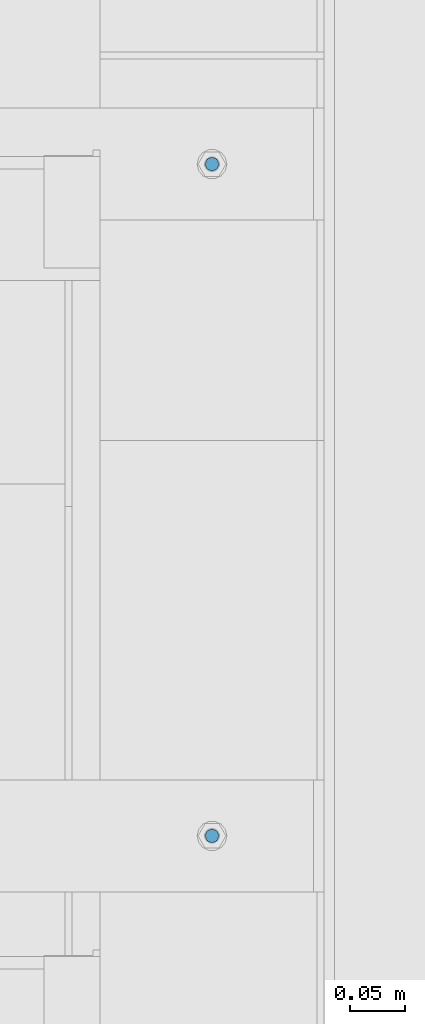
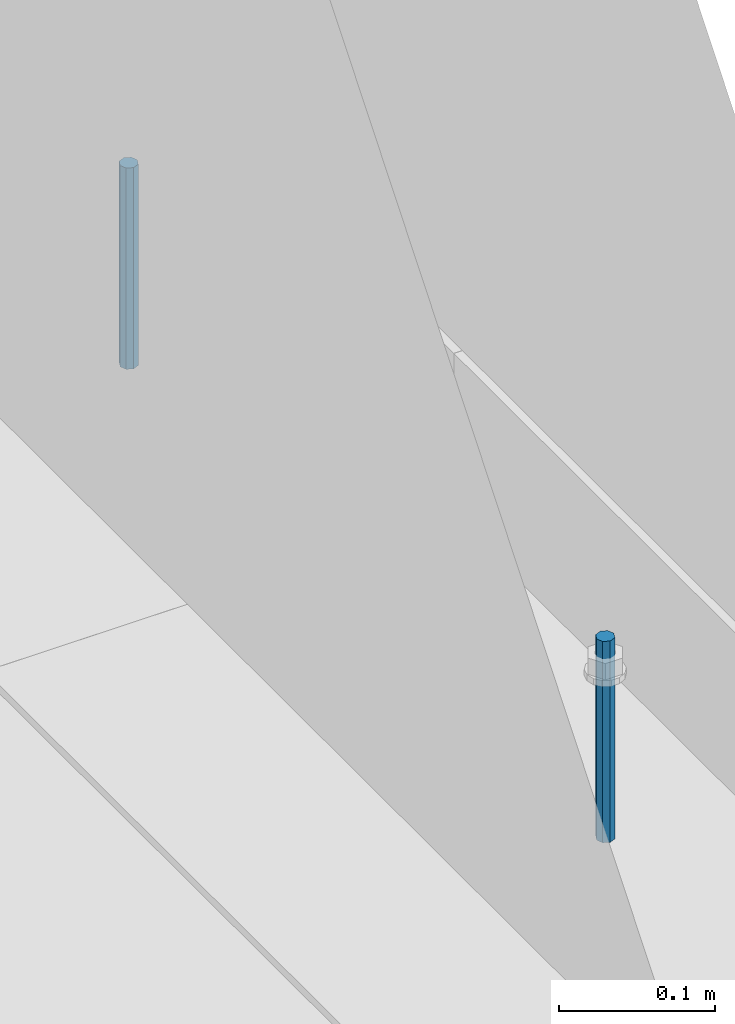
# One storey, part 462 of 1179: 2 columns, 1 element without a shape of its own.
"""IFC2X3 building model written with IfcOpenShell, lengths in millimetres."""

from ifc_helpers import new_model, si_unit, frame, origin_with_axes, place, context, subcontext, project, spatial, faceted_brep, material, type_object, element, aggregate, save


model = new_model("IFC2X3")

# Units and contexts
model_context = context("Model", 3, precision=1e-05, world=origin_with_axes())
body_context = subcontext(model_context, "Body", "Model", "MODEL_VIEW")
ifc_project = project(units=[si_unit("LENGTHUNIT", "METRE", prefix="MILLI"), si_unit("AREAUNIT", "SQUARE_METRE"), si_unit("VOLUMEUNIT", "CUBIC_METRE"), si_unit("MASSUNIT", "GRAM", prefix="KILO"), si_unit("TIMEUNIT", "SECOND"), si_unit("PLANEANGLEUNIT", "RADIAN"), si_unit("SOLIDANGLEUNIT", "STERADIAN"), si_unit("THERMODYNAMICTEMPERATUREUNIT", "DEGREE_CELSIUS"), si_unit("LUMINOUSINTENSITYUNIT", "LUMEN")], contexts=[model_context])

# Site, building, storey
site_placement = place(None, origin_with_axes())
site = spatial("IfcSite", under=ifc_project, at=site_placement, CompositionType="ELEMENT")
building_placement = place(site_placement, origin_with_axes())
building = spatial("IfcBuilding", under=site, at=building_placement, Name="Undefined", CompositionType="ELEMENT")
storey_placement = place(building_placement, origin_with_axes())
storey = spatial("IfcBuildingStorey", under=building, at=storey_placement, Name="Undefined", CompositionType="ELEMENT", Elevation=0.0)

# Assembly, columns
assembly_placement = place(storey_placement, origin_with_axes())
assembly = element("IfcElementAssembly", 1, at=assembly_placement, inside=storey, Name="BEAM", AssemblyPlace="NOTDEFINED", PredefinedType="RIGID_FRAME")
ifc_material = material(Name="STEEL/A307")
column_type = type_object("IfcColumnType", PredefinedType="NOTDEFINED")
column_1_placement = place(assembly_placement, frame((24638.0, 25577.8, 4108.45), z_axis=(0.0, 1.0, 0.0), x_axis=(0.0, 0.0, 1.0)))
column_1 = element("IfcColumn", 2, at=column_1_placement, type_object=column_type, material=ifc_material, Name="THREADED ROD", context=body_context, shape_type="Brep", body=[
    faceted_brep([(0.0, -6.34999999999854, 0.0), (0.0, -4.49012806053361, -4.49012806053452), (157.162499999999, -4.49012806053361, -4.49012806053361), (157.162499999999, -6.34999999999854, 0.0), (0.0, 0.0, -6.34999999999991), (157.162499999999, 0.0, -6.34999999999854), (0.0, 4.49012806053361, -4.49012806053452), (157.162499999999, 4.49012806053361, -4.49012806053361), (0.0, 6.34999999999854, 0.0), (157.162499999999, 6.34999999999854, 0.0), (0.0, 4.49012806053361, 4.49012806053452), (157.162499999999, 4.49012806053361, 4.49012806053361), (0.0, 0.0, 6.34999999999991), (157.162499999999, 0.0, 6.34999999999854), (0.0, -4.49012806053361, 4.49012806053452), (157.162499999999, -4.49012806053361, 4.49012806053361)], [[[0, 1, 2, 3]], [[1, 4, 5, 2]], [[4, 6, 7, 5]], [[6, 8, 9, 7]], [[8, 10, 11, 9]], [[10, 12, 13, 11]], [[12, 14, 15, 13]], [[14, 0, 3, 15]], [[5, 7, 9, 11, 13, 15, 3, 2]], [[14, 12, 10, 8, 6, 4, 1, 0]]]),
])
column_2_placement = place(assembly_placement, frame((24638.0, 24968.2, 4108.45), z_axis=(0.0, 1.0, 0.0), x_axis=(0.0, 0.0, 1.0)))
column_2 = element("IfcColumn", 3, at=column_2_placement, type_object=column_type, material=ifc_material, Name="THREADED ROD", context=body_context, shape_type="Brep", body=[
    faceted_brep([(0.0, -6.34999999999854, 0.0), (0.0, -4.49012806053361, -4.49012806053452), (157.162499999999, -4.49012806053361, -4.49012806053361), (157.162499999999, -6.34999999999854, 0.0), (0.0, 0.0, -6.34999999999991), (157.162499999999, 0.0, -6.34999999999854), (0.0, 4.49012806053361, -4.49012806053452), (157.162499999999, 4.49012806053361, -4.49012806053361), (0.0, 6.34999999999854, 0.0), (157.162499999999, 6.34999999999854, 0.0), (0.0, 4.49012806053361, 4.49012806053452), (157.162499999999, 4.49012806053361, 4.49012806053361), (0.0, 0.0, 6.34999999999991), (157.162499999999, 0.0, 6.34999999999854), (0.0, -4.49012806053361, 4.49012806053452), (157.162499999999, -4.49012806053361, 4.49012806053361)], [[[0, 1, 2, 3]], [[1, 4, 5, 2]], [[4, 6, 7, 5]], [[6, 8, 9, 7]], [[8, 10, 11, 9]], [[10, 12, 13, 11]], [[12, 14, 15, 13]], [[14, 0, 3, 15]], [[5, 7, 9, 11, 13, 15, 3, 2]], [[14, 12, 10, 8, 6, 4, 1, 0]]]),
])
aggregate(assembly, [column_1, column_2])

save(model, "model.ifc")
